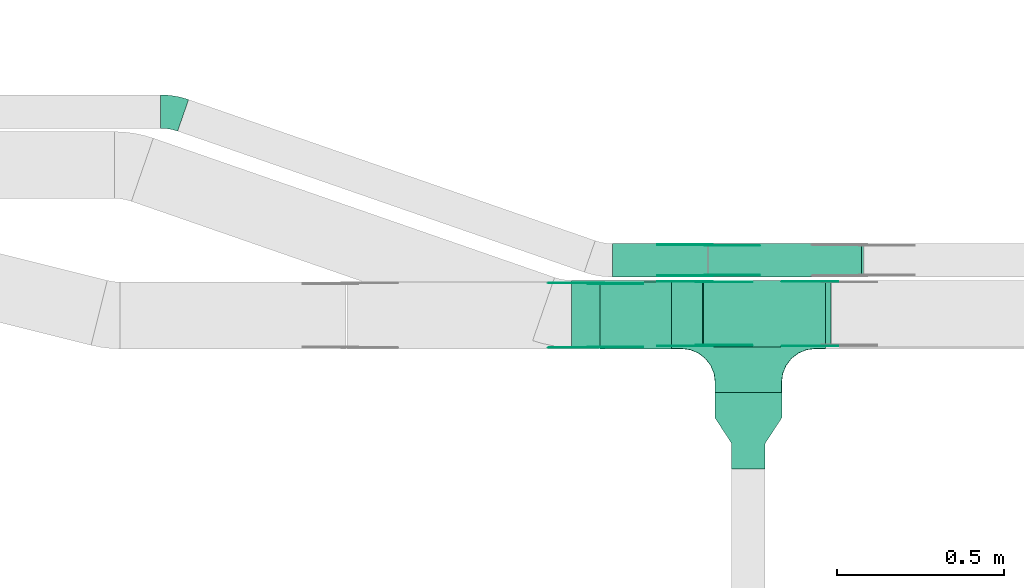
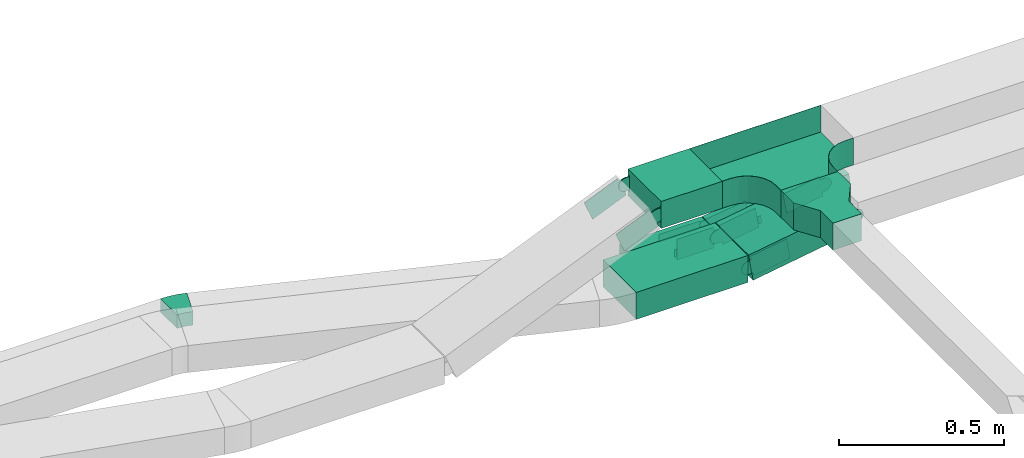
# One storey, part 14 of 25: 17 flow fittings, 5 flow segments.
"""IFC2X3 building model written with IfcOpenShell, lengths in millimetres."""

from ifc_helpers import new_model, entity, si_unit, converted_unit, derived_unit, direction, frame, frame_2d, origin, origin_2d_with_axis, place, context, subcontext, project, spatial, polyline, circle_curve, parameter, trimmed, segment, composite_curve, rectangle, outline, extrude, faceted_brep, source, transform, mapped, material, type_object, type_shapes, element, save


model = new_model("IFC2X3")

# Units and contexts
model_context = context("Model", 3, precision=0.01, world=origin(), true_north=direction((6.12303176911189e-17, 1.0)))
body_context = subcontext(model_context, "Body", "Model", "MODEL_VIEW")
ifc_project = project(units=[si_unit("LENGTHUNIT", "METRE", prefix="MILLI"), si_unit("AREAUNIT", "SQUARE_METRE"), si_unit("VOLUMEUNIT", "CUBIC_METRE"), converted_unit("PLANEANGLEUNIT", "DEGREE", entity("IfcRatioMeasure", 0.0174532925199433), si_unit("PLANEANGLEUNIT", "RADIAN"), dimensions=[0, 0, 0, 0, 0, 0, 0]), si_unit("MASSUNIT", "GRAM", prefix="KILO"), derived_unit("MASSDENSITYUNIT", [(si_unit("MASSUNIT", "GRAM", prefix="KILO"), 1), (si_unit("LENGTHUNIT", "METRE"), -3)]), derived_unit("MOMENTOFINERTIAUNIT", [(si_unit("LENGTHUNIT", "METRE"), 4)]), si_unit("TIMEUNIT", "SECOND"), si_unit("FREQUENCYUNIT", "HERTZ"), si_unit("THERMODYNAMICTEMPERATUREUNIT", "DEGREE_CELSIUS"), derived_unit("THERMALTRANSMITTANCEUNIT", [(si_unit("MASSUNIT", "GRAM", prefix="KILO"), 1), (si_unit("THERMODYNAMICTEMPERATUREUNIT", "KELVIN"), -1), (si_unit("TIMEUNIT", "SECOND"), -3)]), derived_unit("VOLUMETRICFLOWRATEUNIT", [(si_unit("LENGTHUNIT", "METRE"), 3), (si_unit("TIMEUNIT", "SECOND"), -1)]), derived_unit("MASSFLOWRATEUNIT", [(si_unit("MASSUNIT", "GRAM", prefix="KILO"), 1), (si_unit("TIMEUNIT", "SECOND"), -1)]), derived_unit("ROTATIONALFREQUENCYUNIT", [(si_unit("TIMEUNIT", "SECOND"), -1)]), si_unit("ELECTRICCURRENTUNIT", "AMPERE"), si_unit("ELECTRICVOLTAGEUNIT", "VOLT"), si_unit("POWERUNIT", "WATT"), si_unit("FORCEUNIT", "NEWTON", prefix="KILO"), si_unit("ILLUMINANCEUNIT", "LUX"), si_unit("LUMINOUSFLUXUNIT", "LUMEN"), si_unit("LUMINOUSINTENSITYUNIT", "CANDELA"), derived_unit("USERDEFINED", [(si_unit("MASSUNIT", "GRAM", prefix="KILO"), -1), (si_unit("LENGTHUNIT", "METRE"), -2), (si_unit("TIMEUNIT", "SECOND"), 3), (si_unit("LUMINOUSFLUXUNIT", "LUMEN"), 1)]), derived_unit("LINEARVELOCITYUNIT", [(si_unit("LENGTHUNIT", "METRE"), 1), (si_unit("TIMEUNIT", "SECOND"), -1)]), si_unit("PRESSUREUNIT", "PASCAL"), derived_unit("USERDEFINED", [(si_unit("LENGTHUNIT", "METRE"), -2), (si_unit("MASSUNIT", "GRAM", prefix="KILO"), 1), (si_unit("TIMEUNIT", "SECOND"), -2)]), derived_unit("LINEARFORCEUNIT", [(si_unit("MASSUNIT", "GRAM", prefix="KILO"), 1), (si_unit("LENGTHUNIT", "METRE"), 1), (si_unit("TIMEUNIT", "SECOND"), -2), (si_unit("LENGTHUNIT", "METRE"), -1)]), derived_unit("PLANARFORCEUNIT", [(si_unit("MASSUNIT", "GRAM", prefix="KILO"), 1), (si_unit("LENGTHUNIT", "METRE"), 1), (si_unit("TIMEUNIT", "SECOND"), -2), (si_unit("LENGTHUNIT", "METRE"), -2)])], contexts=[model_context])

# Site, building, storey
site_placement = place(None, frame((0.0, -0.00077364408347762, 0.0)))
site = spatial("IfcSite", under=ifc_project, at=site_placement, CompositionType="ELEMENT")
building_placement = place(site_placement, origin())
building = spatial("IfcBuilding", under=site, at=building_placement, CompositionType="ELEMENT")
storey_placement = place(building_placement, frame((0.0, 0.0, 24000.0)))
storey = spatial("IfcBuildingStorey", under=building, at=storey_placement, CompositionType="ELEMENT", Elevation=24000.0)

# Flow segments
cable_carrier_segment_type = type_object("IfcCableCarrierSegmentType", PredefinedType="CABLETRAYSEGMENT")
flow_segment_1_placement = place(storey_placement, frame((40980.8799278763, 8734.98923132583, 2970.0)))
element("IfcFlowSegment", 1, at=flow_segment_1_placement, inside=storey, type_object=cable_carrier_segment_type, context=body_context, shape_type="SweptSolid", body=[
    extrude(rectangle(XDim=214.228543290827, YDim=200.0, at=frame_2d((-4.32720526077901e-12, 0.0), x_axis=(1.0, 0.0))), frame((107.114271645426, 100.0, 0.0), z_axis=(0.0, 0.0, 1.0), x_axis=(-1.0, 0.0, 0.0)), (0.0, 0.0, 1.0), 100.000000000003),
])
flow_segment_2_placement = place(storey_placement, frame((40896.2257007111, 8739.98925078064, 2660.0)))
element("IfcFlowSegment", 2, at=flow_segment_2_placement, inside=storey, type_object=cable_carrier_segment_type, context=body_context, shape_type="SweptSolid", body=[
    extrude(rectangle(XDim=391.57439846643, YDim=200.0, at=origin_2d_with_axis()), frame((195.787199233241, 100.0, 0.0), z_axis=(0.0, 0.0, 1.0), x_axis=(-1.0, 0.0, 0.0)), (0.0, 0.0, 1.0), 99.9999999999989),
])
flow_segment_3_placement = place(storey_placement, frame((41290.4181051559, 8739.98925078073, 2661.45775634341)))
element("IfcFlowSegment", 3, at=flow_segment_3_placement, inside=storey, type_object=cable_carrier_segment_type, context=body_context, shape_type="SweptSolid", body=[
    extrude(rectangle(XDim=99.9999999999997, YDim=200.0, at=origin_2d_with_axis()), frame((7.8813402988073, 100.0, 49.3749377224355), z_axis=(0.987498754448712, 0.0, 0.157626805976146), x_axis=(-0.157626805976146, 0.0, 0.987498754448712)), (0.0, 0.0, 1.0), 370.080529813316),
])
flow_segment_4_placement = place(storey_placement, frame((41017.7971190538, 8949.98925078055, 2660.0)))
element("IfcFlowSegment", 4, at=flow_segment_4_placement, inside=storey, type_object=cable_carrier_segment_type, context=body_context, shape_type="SweptSolid", body=[
    extrude(rectangle(XDim=285.588978631639, YDim=99.9999999999989, at=frame_2d((0.0, -1.08357767203415e-12), x_axis=(1.0, 0.0))), frame((142.79448931582, 50.0, 0.0), z_axis=(0.0, 0.0, 1.0), x_axis=(-1.0, 0.0, 0.0)), (0.0, 0.0, 1.0), 49.9999999999973),
])
flow_segment_5_placement = place(storey_placement, frame((41305.8921701349, 8949.98925078055, 2660.5769366748)))
element("IfcFlowSegment", 5, at=flow_segment_5_placement, inside=storey, type_object=cable_carrier_segment_type, context=body_context, shape_type="SweptSolid", body=[
    extrude(rectangle(XDim=50.0000000000049, YDim=99.9999999999989, at=frame_2d((0.0, 0.0), x_axis=(0.0, 1.0))), frame((3.21484434785989, 50.0, 24.7924338421814), z_axis=(0.991697353687332, 0.0, 0.128593773914383), x_axis=(0.0, 1.0, 0.0)), (0.0, 0.0, 1.0), 460.840810267681),
])

# Flow fittings
ifc_material_1 = material(Name="G")
cable_carrier_fitting_type_1 = type_object("IfcCableCarrierFittingType", PredefinedType="NOTDEFINED", material=ifc_material_1)
shared_shape_1 = source(origin(), body_context, "Body", "SweptSolid", [
    extrude(outline(composite_curve([segment(trimmed(circle_curve(frame_2d((-44.5901162790698, 0.0), x_axis=(1.0, 0.0)), 12.5), [parameter(90.0000000000007)], [parameter(270.0)], True, "PARAMETER"), True, "CONTINUOUS"), segment(polyline([(-44.5901162790697, -12.5), (-33.0901162790698, -12.5)]), True, "CONTINUOUS"), segment(polyline([(-33.0901162790698, -12.5), (-31.2296511627907, -14.5)]), True, "CONTINUOUS"), segment(polyline([(-31.2296511627907, -14.5), (108.90988372093, -14.5)]), True, "CONTINUOUS"), segment(polyline([(108.90988372093, -14.5), (108.90988372093, 14.5)]), True, "CONTINUOUS"), segment(polyline([(108.90988372093, 14.5), (-31.2296511627907, 14.5)]), True, "CONTINUOUS"), segment(polyline([(-31.2296511627907, 14.5), (-33.0901162790698, 12.5)]), True, "CONTINUOUS"), segment(polyline([(-33.0901162790698, 12.5), (-44.5901162790699, 12.5)]), True, "CONTINUOUS")], self_intersect=False)), frame((44.5901162790698, 0.0, 0.0), z_axis=(0.0, 0.0, -1.0), x_axis=(1.0, 0.0, 0.0)), (0.0, 0.0, -1.0), 2.0),
])
type_shapes(cable_carrier_fitting_type_1, [shared_shape_1])
flow_fitting_1_placement = place(storey_placement, frame((41306.2584802724, 9045.44925079071, 2685.0), z_axis=(0.0, 1.0, 0.0), x_axis=(-1.0, 0.0, 0.0)))
element("IfcFlowFitting", 6, at=flow_fitting_1_placement, inside=storey, type_object=cable_carrier_fitting_type_1, material=ifc_material_1, context=body_context, shape_type="MappedRepresentation", body=[
    mapped(shared_shape_1, transform((0.0, 0.0, 0.0), scale=1.0)),
])
cable_carrier_fitting_type_2 = type_object("IfcCableCarrierFittingType", PredefinedType="NOTDEFINED", material=ifc_material_1)
shared_shape_2 = source(origin(), body_context, "Body", "SweptSolid", [
    extrude(outline(composite_curve([segment(trimmed(circle_curve(frame_2d((-44.5901162790697, 0.0), x_axis=(1.0, 0.0)), 12.5), [parameter(90.0000000000007)], [parameter(270.0)], True, "PARAMETER"), True, "CONTINUOUS"), segment(polyline([(-44.5901162790697, -12.5), (-33.0901162790697, -12.5)]), True, "CONTINUOUS"), segment(polyline([(-33.0901162790697, -12.5), (-31.2296511627907, -14.5)]), True, "CONTINUOUS"), segment(polyline([(-31.2296511627907, -14.5), (108.90988372093, -14.5)]), True, "CONTINUOUS"), segment(polyline([(108.90988372093, -14.5), (108.90988372093, 14.5)]), True, "CONTINUOUS"), segment(polyline([(108.90988372093, 14.5), (-31.2296511627907, 14.5)]), True, "CONTINUOUS"), segment(polyline([(-31.2296511627907, 14.5), (-33.0901162790698, 12.5)]), True, "CONTINUOUS"), segment(polyline([(-33.0901162790698, 12.5), (-44.5901162790699, 12.5)]), True, "CONTINUOUS")], self_intersect=False)), frame((44.5901162790697, 0.0, 0.0)), (0.0, 0.0, 1.0), 2.0),
])
type_shapes(cable_carrier_fitting_type_2, [shared_shape_2])
flow_fitting_2_placement = place(storey_placement, frame((41306.2584802724, 8954.52925077039, 2685.0), z_axis=(0.0, -1.0, 0.0), x_axis=(-1.0, 0.0, 0.0)))
element("IfcFlowFitting", 7, at=flow_fitting_2_placement, inside=storey, type_object=cable_carrier_fitting_type_2, material=ifc_material_1, context=body_context, shape_type="MappedRepresentation", body=[
    mapped(shared_shape_2, transform((0.0, 0.0, 0.0), scale=1.0)),
])
cable_carrier_fitting_type_3 = type_object("IfcCableCarrierFittingType", PredefinedType="NOTDEFINED", material=ifc_material_1)
shared_shape_3 = source(origin(), body_context, "Body", "SweptSolid", [
    extrude(outline(composite_curve([segment(trimmed(circle_curve(frame_2d((-44.5901162790698, 0.0), x_axis=(1.0, 0.0)), 12.5), [parameter(90.0000000000007)], [parameter(270.0)], True, "PARAMETER"), True, "CONTINUOUS"), segment(polyline([(-44.5901162790697, -12.5), (-33.0901162790698, -12.5)]), True, "CONTINUOUS"), segment(polyline([(-33.0901162790698, -12.5), (-31.2296511627907, -14.5)]), True, "CONTINUOUS"), segment(polyline([(-31.2296511627907, -14.5), (108.90988372093, -14.5)]), True, "CONTINUOUS"), segment(polyline([(108.90988372093, -14.5), (108.90988372093, 14.5)]), True, "CONTINUOUS"), segment(polyline([(108.90988372093, 14.5), (-31.2296511627907, 14.5)]), True, "CONTINUOUS"), segment(polyline([(-31.2296511627907, 14.5), (-33.0901162790698, 12.5)]), True, "CONTINUOUS"), segment(polyline([(-33.0901162790698, 12.5), (-44.5901162790699, 12.5)]), True, "CONTINUOUS")], self_intersect=False)), frame((44.5901162790698, 0.0, 0.0), z_axis=(0.0, 0.0, -1.0), x_axis=(1.0, 0.0, 0.0)), (0.0, 0.0, -1.0), 2.0),
])
type_shapes(cable_carrier_fitting_type_3, [shared_shape_3])
flow_fitting_3_placement = place(storey_placement, frame((41306.2584802724, 8956.52925077039, 2685.0), z_axis=(0.0, -1.0, 0.0), x_axis=(0.991697353687344, 0.0, 0.128593773914286)))
element("IfcFlowFitting", 8, at=flow_fitting_3_placement, inside=storey, type_object=cable_carrier_fitting_type_3, material=ifc_material_1, context=body_context, shape_type="MappedRepresentation", body=[
    mapped(shared_shape_3, transform((0.0, 0.0, 0.0), scale=1.0)),
])
cable_carrier_fitting_type_4 = type_object("IfcCableCarrierFittingType", PredefinedType="NOTDEFINED", material=ifc_material_1)
shared_shape_4 = source(origin(), body_context, "Body", "SweptSolid", [
    extrude(outline(composite_curve([segment(trimmed(circle_curve(frame_2d((-44.5901162790697, 0.0), x_axis=(1.0, 0.0)), 12.5), [parameter(90.0000000000007)], [parameter(270.0)], True, "PARAMETER"), True, "CONTINUOUS"), segment(polyline([(-44.5901162790697, -12.5), (-33.0901162790697, -12.5)]), True, "CONTINUOUS"), segment(polyline([(-33.0901162790697, -12.5), (-31.2296511627907, -14.5)]), True, "CONTINUOUS"), segment(polyline([(-31.2296511627907, -14.5), (108.90988372093, -14.5)]), True, "CONTINUOUS"), segment(polyline([(108.90988372093, -14.5), (108.90988372093, 14.5)]), True, "CONTINUOUS"), segment(polyline([(108.90988372093, 14.5), (-31.2296511627907, 14.5)]), True, "CONTINUOUS"), segment(polyline([(-31.2296511627907, 14.5), (-33.0901162790698, 12.5)]), True, "CONTINUOUS"), segment(polyline([(-33.0901162790698, 12.5), (-44.5901162790699, 12.5)]), True, "CONTINUOUS")], self_intersect=False)), frame((44.5901162790697, 0.0, 0.0)), (0.0, 0.0, 1.0), 2.0),
])
type_shapes(cable_carrier_fitting_type_4, [shared_shape_4])
flow_fitting_4_placement = place(storey_placement, frame((41306.2584802724, 9043.44925079071, 2685.0), z_axis=(0.0, 1.0, 0.0), x_axis=(0.991697353687344, 0.0, 0.128593773914286)))
element("IfcFlowFitting", 9, at=flow_fitting_4_placement, inside=storey, type_object=cable_carrier_fitting_type_4, material=ifc_material_1, context=body_context, shape_type="MappedRepresentation", body=[
    mapped(shared_shape_4, transform((0.0, 0.0, 0.0), scale=1.0)),
])
cable_carrier_fitting_type_5 = type_object("IfcCableCarrierFittingType", PredefinedType="NOTDEFINED", material=ifc_material_1)
shared_shape_5 = source(origin(), body_context, "Body", "SweptSolid", [
    extrude(outline(composite_curve([segment(trimmed(circle_curve(frame_2d((-41.4651162790697, 0.0), x_axis=(1.0, 0.0)), 25.0), [parameter(90.0000000000007)], [parameter(270.0)], True, "PARAMETER"), True, "CONTINUOUS"), segment(polyline([(-41.4651162790697, -25.0), (-29.9651162790697, -25.0)]), True, "CONTINUOUS"), segment(polyline([(-29.9651162790697, -25.0), (-28.1046511627907, -38.5)]), True, "CONTINUOUS"), segment(polyline([(-28.1046511627907, -38.5), (99.5348837209303, -38.5)]), True, "CONTINUOUS"), segment(polyline([(99.5348837209303, -38.5), (99.5348837209303, 38.5)]), True, "CONTINUOUS"), segment(polyline([(99.5348837209303, 38.5), (-28.1046511627907, 38.5)]), True, "CONTINUOUS"), segment(polyline([(-28.1046511627907, 38.5), (-29.9651162790697, 25.0)]), True, "CONTINUOUS"), segment(polyline([(-29.9651162790697, 25.0), (-41.46511627907, 25.0)]), True, "CONTINUOUS")], self_intersect=False)), frame((41.4651162790697, 0.0, 0.0), z_axis=(0.0, 0.0, -1.0), x_axis=(1.0, 0.0, 0.0)), (0.0, 0.0, -1.0), 2.0),
])
type_shapes(cable_carrier_fitting_type_5, [shared_shape_5])
for number, where, z_axis, x_axis in (
    (10, (40968.9701607067, 8739.52923131576, 3020.0), (0.0, -1.0, 0.0), (-0.921566974007647, 0.0, -0.388219412727376)),
    (11, (41668.9701607069, 8744.52925077057, 2770.0), (0.0, -1.0, 0.0), (-0.98749875444872, 0.0, -0.1576268059761)),
    (12, (41293.0827924389, 8935.44925079089, 2710.0), (0.0, 1.0, 0.0), (-1.0, 0.0, 0.0)),
):
    element("IfcFlowFitting", number, at=place(storey_placement, frame(where, z_axis=z_axis, x_axis=x_axis)), inside=storey, type_object=cable_carrier_fitting_type_5, material=ifc_material_1, context=body_context, shape_type="MappedRepresentation", body=[
        mapped(shared_shape_5, transform((0.0, 0.0, 0.0), scale=1.0)),
    ])
cable_carrier_fitting_type_6 = type_object("IfcCableCarrierFittingType", PredefinedType="NOTDEFINED", material=ifc_material_1)
shared_shape_6 = source(origin(), body_context, "Body", "SweptSolid", [
    extrude(outline(composite_curve([segment(trimmed(circle_curve(frame_2d((-41.4651162790697, 0.0), x_axis=(1.0, 0.0)), 25.0), [parameter(90.0000000000007)], [parameter(270.0)], True, "PARAMETER"), True, "CONTINUOUS"), segment(polyline([(-41.4651162790697, -25.0), (-29.9651162790697, -25.0)]), True, "CONTINUOUS"), segment(polyline([(-29.9651162790697, -25.0), (-28.1046511627907, -38.5)]), True, "CONTINUOUS"), segment(polyline([(-28.1046511627907, -38.5), (99.5348837209303, -38.5)]), True, "CONTINUOUS"), segment(polyline([(99.5348837209303, -38.5), (99.5348837209303, 38.5)]), True, "CONTINUOUS"), segment(polyline([(99.5348837209303, 38.5), (-28.1046511627907, 38.5)]), True, "CONTINUOUS"), segment(polyline([(-28.1046511627907, 38.5), (-29.9651162790697, 25.0)]), True, "CONTINUOUS"), segment(polyline([(-29.9651162790697, 25.0), (-41.46511627907, 25.0)]), True, "CONTINUOUS")], self_intersect=False)), frame((41.4651162790697, 0.0, 0.0)), (0.0, 0.0, 1.0), 2.0),
])
type_shapes(cable_carrier_fitting_type_6, [shared_shape_6])
for number, where, z_axis, x_axis in (
    (13, (40968.9701607067, 8930.44923133608, 3020.0), (0.0, 1.0, 0.0), (-0.921566974007647, 0.0, -0.388219412727376)),
    (14, (41668.9701607069, 8935.44925079089, 2770.0), (0.0, 1.0, 0.0), (-0.98749875444872, 0.0, -0.1576268059761)),
    (15, (41293.0827924389, 8744.52925077058, 2710.0), (0.0, -1.0, 0.0), (-1.0, 0.0, 0.0)),
):
    element("IfcFlowFitting", number, at=place(storey_placement, frame(where, z_axis=z_axis, x_axis=x_axis)), inside=storey, type_object=cable_carrier_fitting_type_6, material=ifc_material_1, context=body_context, shape_type="MappedRepresentation", body=[
        mapped(shared_shape_6, transform((0.0, 0.0, 0.0), scale=1.0)),
    ])
cable_carrier_fitting_type_7 = type_object("IfcCableCarrierFittingType", PredefinedType="NOTDEFINED", material=ifc_material_1)
shared_shape_7 = source(origin(), body_context, "Body", "SweptSolid", [
    extrude(outline(composite_curve([segment(trimmed(circle_curve(frame_2d((-41.4651162790697, 0.0), x_axis=(1.0, 0.0)), 25.0), [parameter(90.0000000000007)], [parameter(270.0)], True, "PARAMETER"), True, "CONTINUOUS"), segment(polyline([(-41.4651162790697, -25.0), (-29.9651162790697, -25.0)]), True, "CONTINUOUS"), segment(polyline([(-29.9651162790697, -25.0), (-28.1046511627907, -38.5)]), True, "CONTINUOUS"), segment(polyline([(-28.1046511627907, -38.5), (99.5348837209303, -38.5)]), True, "CONTINUOUS"), segment(polyline([(99.5348837209303, -38.5), (99.5348837209303, 38.5)]), True, "CONTINUOUS"), segment(polyline([(99.5348837209303, 38.5), (-28.1046511627907, 38.5)]), True, "CONTINUOUS"), segment(polyline([(-28.1046511627907, 38.5), (-29.9651162790697, 25.0)]), True, "CONTINUOUS"), segment(polyline([(-29.9651162790697, 25.0), (-41.46511627907, 25.0)]), True, "CONTINUOUS")], self_intersect=False)), frame((41.4651162790697, 0.0, 0.0), z_axis=(0.0, 0.0, -1.0), x_axis=(1.0, 0.0, 0.0)), (0.0, 0.0, -1.0), 2.0),
])
type_shapes(cable_carrier_fitting_type_7, [shared_shape_7])
for number, where, z_axis, x_axis in (
    (16, (40968.9701607067, 8928.44923133607, 3020.0), (0.0, 1.0, 0.0), (1.0, 0.0, 0.0)),
    (17, (41293.0827924389, 8746.52925077058, 2710.0), (0.0, -1.0, 0.0), (0.987498754448717, 0.0, 0.157626805976115)),
):
    element("IfcFlowFitting", number, at=place(storey_placement, frame(where, z_axis=z_axis, x_axis=x_axis)), inside=storey, type_object=cable_carrier_fitting_type_7, material=ifc_material_1, context=body_context, shape_type="MappedRepresentation", body=[
        mapped(shared_shape_7, transform((0.0, 0.0, 0.0), scale=1.0)),
    ])
cable_carrier_fitting_type_8 = type_object("IfcCableCarrierFittingType", PredefinedType="NOTDEFINED", material=ifc_material_1)
shared_shape_8 = source(origin(), body_context, "Body", "SweptSolid", [
    extrude(outline(composite_curve([segment(trimmed(circle_curve(frame_2d((-41.4651162790697, 0.0), x_axis=(1.0, 0.0)), 25.0), [parameter(90.0000000000007)], [parameter(270.0)], True, "PARAMETER"), True, "CONTINUOUS"), segment(polyline([(-41.4651162790697, -25.0), (-29.9651162790697, -25.0)]), True, "CONTINUOUS"), segment(polyline([(-29.9651162790697, -25.0), (-28.1046511627907, -38.5)]), True, "CONTINUOUS"), segment(polyline([(-28.1046511627907, -38.5), (99.5348837209303, -38.5)]), True, "CONTINUOUS"), segment(polyline([(99.5348837209303, -38.5), (99.5348837209303, 38.5)]), True, "CONTINUOUS"), segment(polyline([(99.5348837209303, 38.5), (-28.1046511627907, 38.5)]), True, "CONTINUOUS"), segment(polyline([(-28.1046511627907, 38.5), (-29.9651162790697, 25.0)]), True, "CONTINUOUS"), segment(polyline([(-29.9651162790697, 25.0), (-41.46511627907, 25.0)]), True, "CONTINUOUS")], self_intersect=False)), frame((41.4651162790697, 0.0, 0.0)), (0.0, 0.0, 1.0), 2.0),
])
type_shapes(cable_carrier_fitting_type_8, [shared_shape_8])
for number, where, z_axis, x_axis in (
    (18, (40968.9701607067, 8741.52923131576, 3020.0), (0.0, -1.0, 0.0), (1.0, 0.0, 0.0)),
    (19, (41293.0827924389, 8933.44925079089, 2710.0), (0.0, 1.0, 0.0), (0.987498754448717, 0.0, 0.157626805976115)),
):
    element("IfcFlowFitting", number, at=place(storey_placement, frame(where, z_axis=z_axis, x_axis=x_axis)), inside=storey, type_object=cable_carrier_fitting_type_8, material=ifc_material_1, context=body_context, shape_type="MappedRepresentation", body=[
        mapped(shared_shape_8, transform((0.0, 0.0, 0.0), scale=1.0)),
    ])
ifc_material_2 = material()
cable_carrier_fitting_type_9 = type_object("IfcCableCarrierFittingType", PredefinedType="NOTDEFINED", material=ifc_material_2)
shared_shape_9 = source(origin(), body_context, "Body", "Brep", [
    faceted_brep([(-103.407417371087, -174.118095489753, 50.0), (-100.0, -200.0, 50.0), (-100.0, -230.0, 50.0), (-99.1999999999932, -230.0, 50.0), (-99.1999999999933, -200.0, 50.0), (-102.634676710055, -173.911040253671, 50.0), (-112.704639298522, -149.600000000004, 50.0), (-128.723636456391, -128.7236364564, 50.0), (-149.599999999996, -112.704639298532, 50.0), (-173.911040253663, -102.634676710066, 50.0), (-200.0, -99.2000000000044, 50.0), (-230.0, -99.2000000000044, 50.0), (-230.0, -100.0, 50.0), (-200.0, -100.0, 50.0), (-174.118095489746, -103.407417371099, 50.0), (-150.0, -113.397459621561, 50.0), (-129.28932188134, -129.28932188135, 50.0), (-113.39745962155, -150.0, 50.0), (230.0, -100.0, 50.0), (230.0, -99.2000000000044, 50.0), (200.0, -99.2000000000097, 50.0), (173.911040253722, -102.634676710071, 50.0), (149.60000000005, -112.704639298537, 50.0), (128.723636456439, -128.723636456403, 50.0), (112.704639298563, -149.600000000006, 50.0), (102.634676710086, -173.911040253673, 50.0), (99.2000000000121, -200.0, 50.0), (99.2000000000069, -230.0, 50.0), (100.0, -230.0, 50.0), (100.0, -200.0, 50.0), (103.407417371119, -174.118095489755, 50.0), (113.397459621593, -150.0, 50.0), (129.289321881391, -129.289321881354, 50.0), (150.0, -113.397459621567, 50.0), (174.118095489805, -103.407417371105, 50.0), (200.0, -100.0, 50.0), (230.0, 99.1999999999954, 50.0), (230.0, 100.0, 50.0), (-230.0, 100.0, 50.0), (-230.0, 99.1999999999954, 50.0), (-230.0, -100.0, -50.0), (-230.0, 100.0, -50.0), (230.0, 100.0, -50.0), (230.0, -100.0, -50.0), (200.0, -100.0, -50.0), (174.118095489805, -103.407417371105, -50.0), (150.0, -113.397459621567, -50.0), (129.289321881391, -129.289321881354, -50.0), (113.397459621593, -150.0, -50.0), (103.407417371119, -174.118095489755, -50.0), (100.0, -200.0, -50.0), (100.0, -230.0, -50.0), (-100.0, -230.0, -50.0), (-100.0, -200.0, -50.0), (-103.407417371087, -174.118095489753, -50.0), (-113.39745962155, -150.0, -50.0), (-129.28932188134, -129.28932188135, -50.0), (-150.0, -113.397459621561, -50.0), (-174.118095489746, -103.407417371099, -50.0), (-200.0, -100.0, -50.0), (-100.0, -200.0, -49.1999999999851), (99.2000000000069, -230.0, -49.1999999999851), (-99.1999999999932, -230.0, -49.1999999999851), (-99.1999999999933, -200.0, -49.1999999999851), (-200.0, -99.2000000000044, -49.1999999999851), (-230.0, -99.2000000000044, -49.1999999999851), (230.0, -99.2000000000044, -49.1999999999851), (200.0, -99.2000000000044, -49.1999999999851), (-230.0, 99.1999999999954, -49.1999999999851), (-200.0, -100.0, -49.1999999999851), (200.0, -100.0, -49.1999999999851), (230.0, 99.1999999999954, -49.1999999999851), (99.2000000000121, -200.0, -49.1999999999851), (100.0, -200.0, -49.1999999999851), (-173.911040253663, -102.634676710066, -49.1999999999851), (-149.599999999996, -112.704639298532, -49.1999999999851), (-128.723636456391, -128.7236364564, -49.1999999999851), (-112.704639298522, -149.600000000004, -49.1999999999851), (-102.634676710055, -173.911040253671, -49.1999999999851), (102.634676710086, -173.911040253674, -49.1999999999851), (112.704639298563, -149.600000000007, -49.1999999999851), (128.723636456439, -128.723636456403, -49.1999999999851), (149.60000000005, -112.704639298537, -49.1999999999851), (173.911040253721, -102.634676710071, -49.1999999999851)], [[[0, 1, 2, 3, 4, 5, 6, 7, 8, 9, 10, 11, 12, 13, 14, 15, 16, 17]], [[18, 19, 20, 21, 22, 23, 24, 25, 26, 27, 28, 29, 30, 31, 32, 33, 34, 35]], [[36, 37, 38, 39]], [[40, 41, 42, 43, 44, 45, 46, 47, 48, 49, 50, 51, 52, 53, 54, 55, 56, 57, 58, 59]], [[2, 1, 60, 53, 52]], [[3, 2, 52, 51, 28, 27, 61, 62]], [[4, 3, 62, 63]], [[11, 10, 64, 65]], [[20, 19, 66, 67]], [[39, 38, 41, 40, 12, 11, 65, 68]], [[13, 12, 40, 59, 69]], [[18, 35, 70, 44, 43]], [[19, 18, 43, 42, 37, 36, 71, 66]], [[27, 26, 72, 61]], [[29, 28, 51, 50, 73]], [[38, 37, 42, 41]], [[36, 39, 68, 71]], [[68, 65, 64, 74, 75, 76, 77, 78, 63, 62, 61, 72, 79, 80, 81, 82, 83, 67, 66, 71]], [[14, 13, 69, 59, 58]], [[15, 14, 58, 57]], [[57, 56, 16, 15]], [[17, 16, 56, 55]], [[0, 17, 55, 54]], [[1, 0, 54, 53, 60]], [[5, 78, 77, 6]], [[6, 77, 76, 7]], [[63, 78, 5, 4]], [[8, 75, 74, 9]], [[9, 74, 64, 10]], [[7, 76, 75, 8]], [[21, 83, 82, 22]], [[22, 82, 81, 23]], [[67, 83, 21, 20]], [[24, 80, 79, 25]], [[25, 79, 72, 26]], [[23, 81, 80, 24]], [[30, 29, 73, 50, 49]], [[31, 30, 49, 48]], [[32, 31, 48, 47]], [[34, 33, 46, 45]], [[34, 45, 44, 70, 35]], [[46, 33, 32, 47]]]),
])
type_shapes(cable_carrier_fitting_type_9, [shared_shape_9])
flow_fitting_5_placement = place(storey_placement, frame((41425.1084711671, 8834.98923132584, 3020.0)))
element("IfcFlowFitting", 20, at=flow_fitting_5_placement, inside=storey, type_object=cable_carrier_fitting_type_9, material=ifc_material_2, Name="470_DKC_S5_T", context=body_context, shape_type="MappedRepresentation", body=[
    mapped(shared_shape_9, transform((0.0, 0.0, 0.0), scale=1.0)),
])
cable_carrier_fitting_type_10 = type_object("IfcCableCarrierFittingType", PredefinedType="NOTDEFINED", material=ifc_material_2)
shared_shape_10 = source(origin(), body_context, "Body", "SweptSolid", [
    extrude(outline(polyline([(-115.0, -100.0), (-38.3333333333284, -100.0), (38.3333333333252, -50.0), (115.0, -50.0), (115.0, 50.0), (38.3333333333382, 50.0), (-38.3333333333284, 100.0), (-115.0, 100.0), (-115.0, -100.0)])), frame((115.0, 0.0, -50.0)), (0.0, 0.0, 1.0), 100.0),
])
type_shapes(cable_carrier_fitting_type_10, [shared_shape_10])
flow_fitting_6_placement = place(storey_placement, frame((41425.1084711671, 8604.98923132584, 3020.0), z_axis=(0.0, 0.0, 1.0), x_axis=(0.0, -1.0, 0.0)))
element("IfcFlowFitting", 21, at=flow_fitting_6_placement, inside=storey, type_object=cable_carrier_fitting_type_10, material=ifc_material_2, Name="470_DKC_S5_adapter", context=body_context, shape_type="MappedRepresentation", body=[
    mapped(shared_shape_10, transform((0.0, 0.0, 0.0), scale=1.0)),
])
cable_carrier_fitting_type_11 = type_object("IfcCableCarrierFittingType", Name="470_DKC_S5_Variable Angle Elbow 0-45:-", PredefinedType="NOTDEFINED", material=ifc_material_2)
shared_shape_11 = source(origin(), body_context, "Body", "SweptSolid", [
    extrude(outline(composite_curve([segment(polyline([(-33.7689431713065, -55.6082000815214), (-32.7689431713052, -55.6082000815214)]), True, "CONTINUOUS"), segment(trimmed(circle_curve(frame_2d((-32.7689431713056, 194.391799918478), x_axis=(0.0, -1.0)), 250.0), [parameter(0.0)], [parameter(19.1369718416102)], True, "PARAMETER"), True, "CONTINUOUS"), segment(polyline([(49.187953776862, -41.7925921200882), (50.132691345016, -41.4647645322956)]), True, "CONTINUOUS"), segment(polyline([(50.132691345016, -41.4647645322956), (17.3499325657494, 53.0089922831311)]), True, "CONTINUOUS"), segment(polyline([(17.3499325657494, 53.0089922831311), (16.4051949975949, 52.6811646953384)]), True, "CONTINUOUS"), segment(trimmed(circle_curve(frame_2d((-32.7689431713056, 194.391799918478), x_axis=(0.0, -1.0)), 150.0), [parameter(0.0)], [parameter(19.1369718416102)], True, "PARAMETER"), False, "CONTINUOUS"), segment(polyline([(-32.7689431713052, 44.3917999184785), (-33.7689431713065, 44.3917999184785)]), True, "CONTINUOUS"), segment(polyline([(-33.7689431713065, 44.3917999184785), (-33.7689431713065, -55.6082000815214)]), True, "CONTINUOUS")], self_intersect=False)), frame((-0.945383446420344, 5.60820008151336, -25.0)), (0.0, 0.0, 1.0), 50.0000000000001),
])
type_shapes(cable_carrier_fitting_type_11, [shared_shape_11])
flow_fitting_7_placement = place(storey_placement, frame((39700.8109504707, 9444.94253623871, 2685.0), z_axis=(0.0, 0.0, 1.0), x_axis=(-0.944737568154257, 0.327827587792701, 0.0)))
element("IfcFlowFitting", 22, at=flow_fitting_7_placement, inside=storey, type_object=cable_carrier_fitting_type_11, material=ifc_material_2, Name="470_DKC_S5_Variable Angle Elbow 0-45:-", ObjectType="470_DKC_S5_Variable Angle Elbow 0-45:-", context=body_context, shape_type="MappedRepresentation", body=[
    mapped(shared_shape_11, transform((0.0, 0.0, 0.0), scale=1.0)),
])

save(model, "model.ifc")
